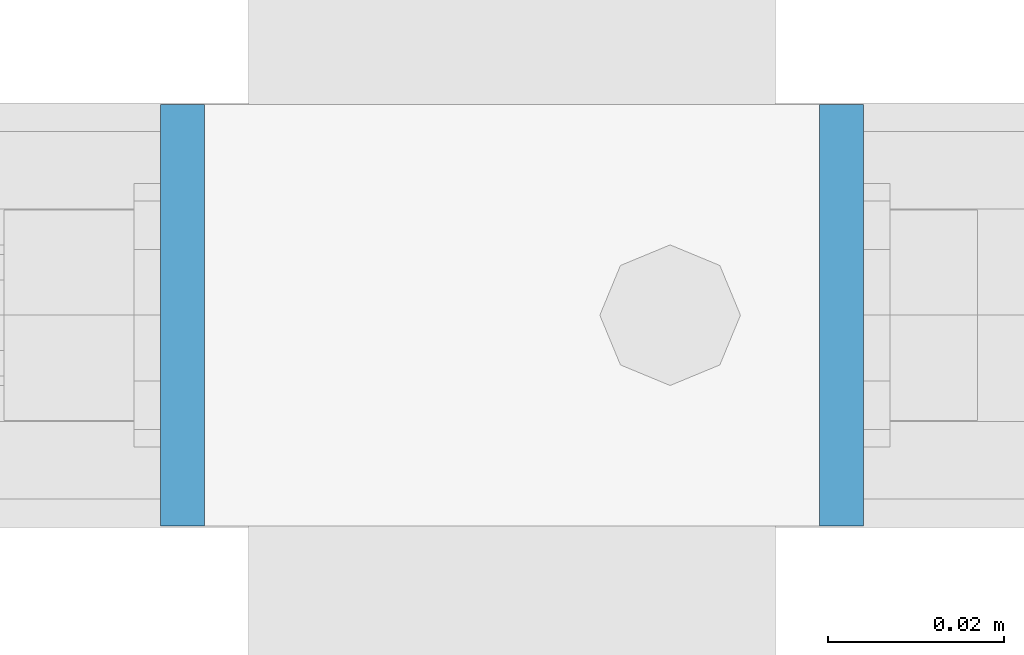
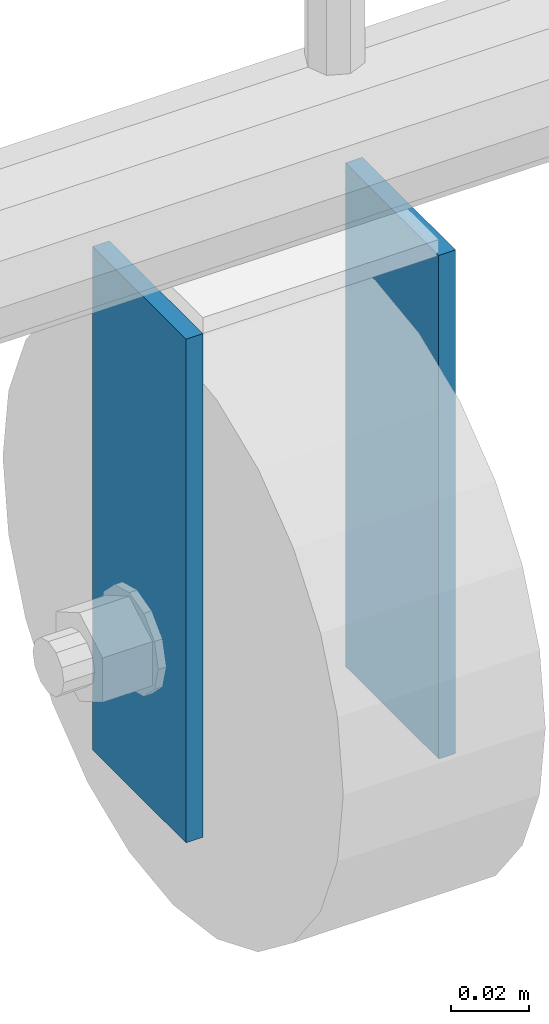
# One storey, part 229 of 247: 2 plates.
"""IFC2X3 building model written with IfcOpenShell, lengths in millimetres."""

from ifc_helpers import new_model, si_unit, frame, origin_with_axes, place, context, subcontext, project, spatial, faceted_brep, material, type_object, element, save


model = new_model("IFC2X3")

# Units and contexts
model_context = context("Model", 3, precision=1e-05, world=origin_with_axes())
body_context = subcontext(model_context, "Body", "Model", "MODEL_VIEW")
ifc_project = project(units=[si_unit("LENGTHUNIT", "METRE", prefix="MILLI"), si_unit("AREAUNIT", "SQUARE_METRE"), si_unit("VOLUMEUNIT", "CUBIC_METRE"), si_unit("MASSUNIT", "GRAM", prefix="KILO"), si_unit("TIMEUNIT", "SECOND"), si_unit("PLANEANGLEUNIT", "RADIAN"), si_unit("SOLIDANGLEUNIT", "STERADIAN"), si_unit("THERMODYNAMICTEMPERATUREUNIT", "DEGREE_CELSIUS"), si_unit("LUMINOUSINTENSITYUNIT", "LUMEN")], contexts=[model_context])

# Site, building, storey
site_placement = place(None, origin_with_axes())
site = spatial("IfcSite", under=ifc_project, at=site_placement, CompositionType="ELEMENT")
building_placement = place(site_placement, origin_with_axes())
building = spatial("IfcBuilding", under=site, at=building_placement, Name="Standard", CompositionType="ELEMENT")
storey_placement = place(building_placement, origin_with_axes())
storey = spatial("IfcBuildingStorey", under=building, at=storey_placement, Name="Undefined", CompositionType="ELEMENT", Elevation=0.0)

# Plates
ifc_material = material(Name="STEEL/S355J2")
plate_type = type_object("IfcPlateType", PredefinedType="NOTDEFINED")
for number, where, z_axis, x_axis in (
    (1, (30016.5962706934, 5965.85337247848, 195.500013088924), (0.0, 0.0, -1.0), (0.0, -0.999999999999548, -9.5100000000016e-07)),
    (2, (30091.5962706934, 5965.85337247848, 195.500013088924), (0.0, 0.0, -1.0), (0.0, -0.999999999999548, -9.5100000000016e-07)),
):
    element("IfcPlate", number, at=place(storey_placement, frame(where, z_axis=z_axis, x_axis=x_axis)), inside=storey, type_object=plate_type, material=ifc_material, context=body_context, shape_type="Brep", body=[
        faceted_brep([(0.0, -2.49999999999909, 0.0), (0.0, -2.5, 158.0), (0.0, 2.5, 158.0), (0.0, 2.5, -9.09494701772928e-13), (48.0, -2.5, 158.0), (48.0, 2.5, 158.0), (48.0, -2.5, 0.0), (48.0, 2.5, 0.0)], [[[0, 1, 2, 3]], [[1, 4, 5, 2]], [[4, 6, 7, 5]], [[6, 0, 3, 7]], [[5, 7, 3, 2]], [[6, 4, 1, 0]]]),
    ])

save(model, "model.ifc")
